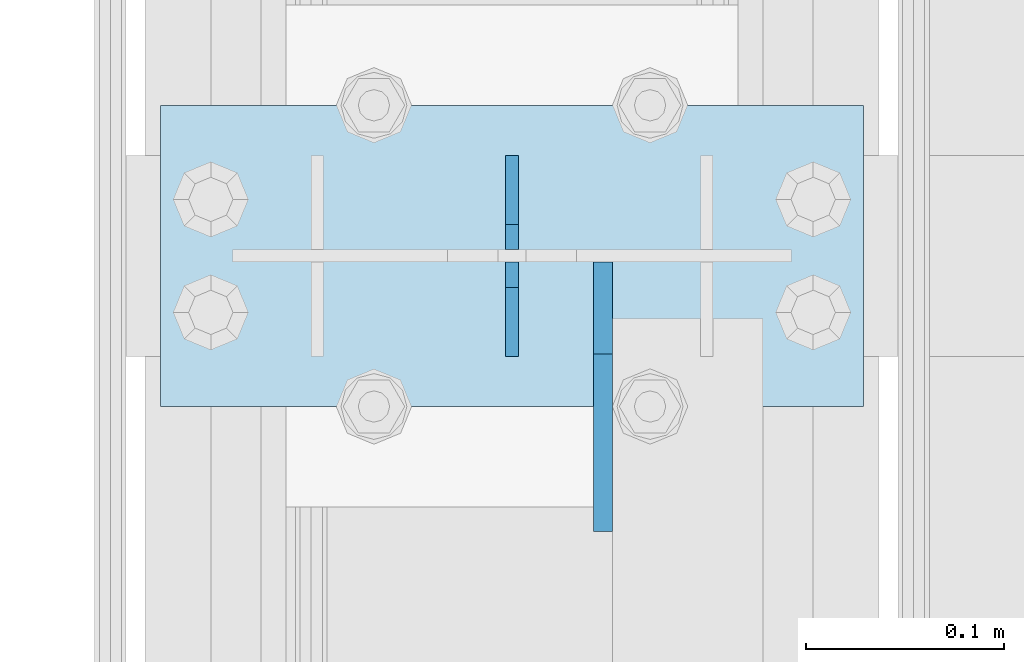
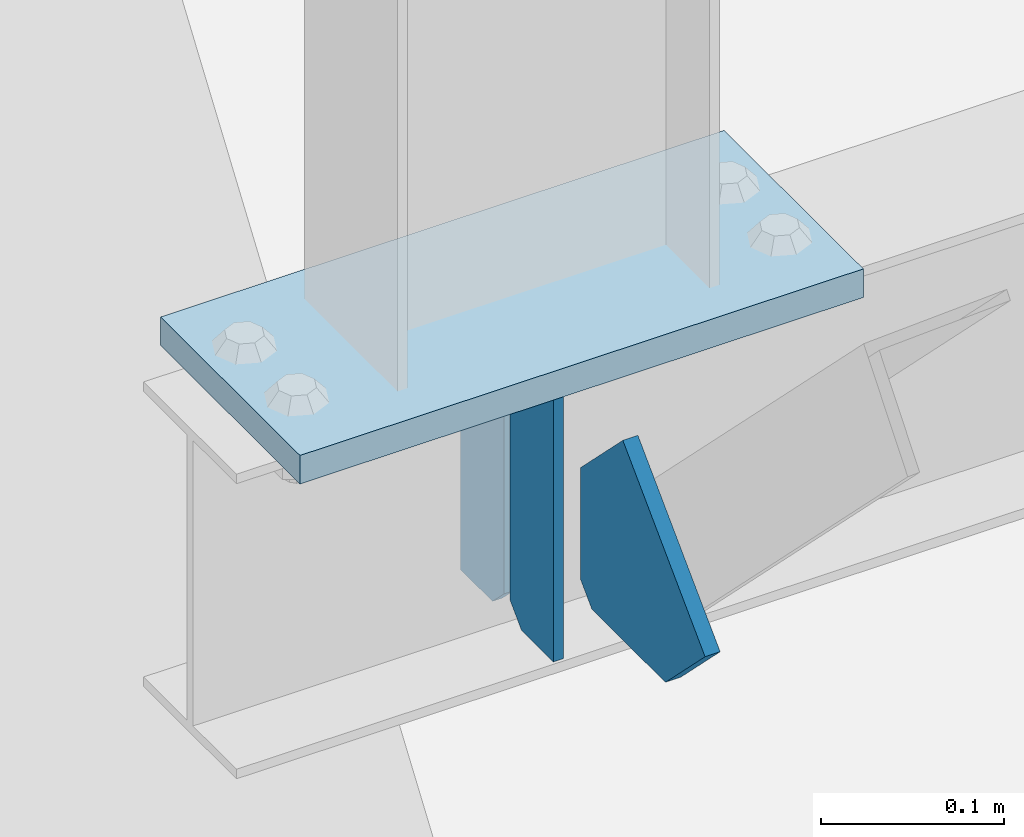
# One storey, part 3359 of 3843: 4 plates, 2 elements without a shape of their own.
"""IFC2X3 building model written with IfcOpenShell, lengths in millimetres."""

from ifc_helpers import new_model, si_unit, frame, origin_with_axes, place, context, subcontext, project, spatial, faceted_brep, material, type_object, element, aggregate, save


model = new_model("IFC2X3")

# Units and contexts
model_context = context("Model", 3, precision=1e-05, world=origin_with_axes())
body_context = subcontext(model_context, "Body", "Model", "MODEL_VIEW")
ifc_project = project(units=[si_unit("LENGTHUNIT", "METRE", prefix="MILLI"), si_unit("AREAUNIT", "SQUARE_METRE"), si_unit("VOLUMEUNIT", "CUBIC_METRE"), si_unit("MASSUNIT", "GRAM", prefix="KILO"), si_unit("TIMEUNIT", "SECOND"), si_unit("PLANEANGLEUNIT", "RADIAN"), si_unit("SOLIDANGLEUNIT", "STERADIAN"), si_unit("THERMODYNAMICTEMPERATUREUNIT", "DEGREE_CELSIUS"), si_unit("LUMINOUSINTENSITYUNIT", "LUMEN")], contexts=[model_context])

# Site, building, storey
site_placement = place(None, origin_with_axes())
site = spatial("IfcSite", under=ifc_project, at=site_placement, CompositionType="ELEMENT")
building_placement = place(site_placement, origin_with_axes())
building = spatial("IfcBuilding", under=site, at=building_placement, Name="Undefined", CompositionType="ELEMENT")
storey_placement = place(building_placement, origin_with_axes())
storey = spatial("IfcBuildingStorey", under=building, at=storey_placement, Name="Undefined", CompositionType="ELEMENT", Elevation=0.0)

# Assembly, plates
assembly_1_placement = place(storey_placement, origin_with_axes())
assembly_1 = element("IfcElementAssembly", 1, at=assembly_1_placement, inside=storey, Name="BEAM", AssemblyPlace="NOTDEFINED", PredefinedType="RIGID_FRAME")
ifc_material = material(Name="STEEL/A572-50")
plate_type_1 = type_object("IfcPlateType", PredefinedType="NOTDEFINED")
plate_1_placement = place(assembly_1_placement, frame((36576.0000030517, 74307.7, 41495.6625), z_axis=(0.0, 0.0, -1.0), x_axis=(0.0, -1.0, 0.0)))
plate_1 = element("IfcPlate", 2, at=plate_1_placement, type_object=plate_type_1, material=ifc_material, Name="PLATE", context=body_context, shape_type="Brep", body=[
    faceted_brep([(0.0, -3.17499999999927, 0.0), (0.0, -3.17500000000291, 187.324999999997), (0.0, 3.17500000000291, 187.324999999997), (0.0, 3.17499999999927, 0.0), (34.9250001907349, -3.17500000000291, 187.324999999997), (34.9250001907349, 3.17500000000291, 187.324999999997), (47.625, -3.17500000000291, 174.625000190732), (47.625, 3.17500000000291, 174.625000190732), (47.625, -3.17499999999927, 12.6999998092651), (47.625, 3.17499999999927, 12.6999998092651), (34.9250001907349, -3.17499999999927, 0.0), (34.9250001907349, 3.17499999999927, 0.0)], [[[0, 1, 2, 3]], [[1, 4, 5, 2]], [[4, 6, 7, 5]], [[6, 8, 9, 7]], [[8, 10, 11, 9]], [[10, 0, 3, 11]], [[5, 7, 9, 11, 3, 2]], [[10, 8, 6, 4, 1, 0]]]),
])
plate_2_placement = place(assembly_1_placement, frame((36576.0000030517, 74206.1, 41495.6625), z_axis=(0.0, 0.0, -1.0), x_axis=(0.0, 1.0, 0.0)))
plate_2 = element("IfcPlate", 3, at=plate_2_placement, type_object=plate_type_1, material=ifc_material, Name="PLATE", context=body_context, shape_type="Brep", body=[
    faceted_brep([(0.0, -3.17499999999927, 0.0), (0.0, -3.17500000000291, 187.324999999997), (0.0, 3.17500000000291, 187.324999999997), (0.0, 3.17499999999927, 0.0), (34.9250001907349, -3.17500000000291, 187.324999999997), (34.9250001907349, 3.17500000000291, 187.324999999997), (47.625, -3.17500000000291, 174.625000190732), (47.625, 3.17500000000291, 174.625000190732), (47.625, -3.17499999999927, 12.6999998092651), (47.625, 3.17499999999927, 12.6999998092651), (34.9250001907349, -3.17499999999927, 0.0), (34.9250001907349, 3.17499999999927, 0.0)], [[[0, 1, 2, 3]], [[1, 4, 5, 2]], [[4, 6, 7, 5]], [[6, 8, 9, 7]], [[8, 10, 11, 9]], [[10, 0, 3, 11]], [[5, 7, 9, 11, 3, 2]], [[10, 8, 6, 4, 1, 0]]]),
])

# Assembly, plate
assembly_2_placement = place(storey_placement, origin_with_axes())
assembly_2 = element("IfcElementAssembly", 4, at=assembly_2_placement, inside=storey, Name="POST", AssemblyPlace="NOTDEFINED", PredefinedType="RIGID_FRAME")
plate_type_2 = type_object("IfcPlateType", PredefinedType="NOTDEFINED")
plate_3_placement = place(assembly_2_placement, frame((36753.8000030518, 74180.7, 41513.125), z_axis=(-1.0, 0.0, 0.0), x_axis=(0.0, 1.0, 0.0)))
plate_3 = element("IfcPlate", 5, at=plate_3_placement, type_object=plate_type_2, material=ifc_material, Name="PLATE", context=body_context, shape_type="Brep", body=[
    faceted_brep([(0.0, -9.52500000000146, 0.0), (0.0, -9.52500000000146, 355.599999999999), (0.0, 9.52500000000146, 355.599999999999), (0.0, 9.52500000000146, 0.0), (152.399999999994, -9.52500000000146, 355.599999999999), (152.399999999994, 9.52500000000146, 355.599999999999), (152.400000000001, -9.52500000000146, 0.0), (152.400000000001, 9.52500000000146, 0.0)], [[[0, 1, 2, 3]], [[1, 4, 5, 2]], [[4, 6, 7, 5]], [[6, 0, 3, 7]], [[5, 7, 3, 2]], [[6, 4, 1, 0]]]),
])
aggregate(assembly_2, [plate_3])

# Plate
plate_type_3 = type_object("IfcPlateType", PredefinedType="NOTDEFINED")
plate_4_placement = place(assembly_1_placement, frame((36622.0375, 74253.725, 41306.75), z_axis=(0.0, -1.0, 0.0), x_axis=(0.0, 0.0, 1.0)))
plate_4 = element("IfcPlate", 6, at=plate_4_placement, type_object=plate_type_3, material=ifc_material, Name="PLATE", context=body_context, shape_type="Brep", body=[
    faceted_brep([(0.0, -4.76250000000073, 12.6999998092651), (4.450703272596e-08, -4.76249999999709, 93.0710244828806), (4.450703272596e-08, 4.76249999999709, 93.0710244828806), (0.0, 4.76250000000073, 12.6999998092651), (43.3137807601452, -4.76249999999709, 136.384805065652), (43.3137807601452, 4.76249999999709, 136.384805065652), (133.209805202001, -4.76249999999709, 46.4887805392646), (133.209805202001, 4.76249999999709, 46.4887805392646), (86.7210245267561, -4.76249999999709, 0.0), (86.7210245267561, 4.76249999999709, 0.0), (12.6999998092651, -4.76250000000073, 0.0), (12.6999998092651, 4.76250000000073, 0.0)], [[[0, 1, 2, 3]], [[1, 4, 5, 2]], [[4, 6, 7, 5]], [[6, 8, 9, 7]], [[8, 10, 11, 9]], [[10, 0, 3, 11]], [[5, 7, 9, 11, 3, 2]], [[10, 8, 6, 4, 1, 0]]]),
])

aggregate(assembly_1, [plate_1, plate_2, plate_4])

save(model, "model.ifc")
